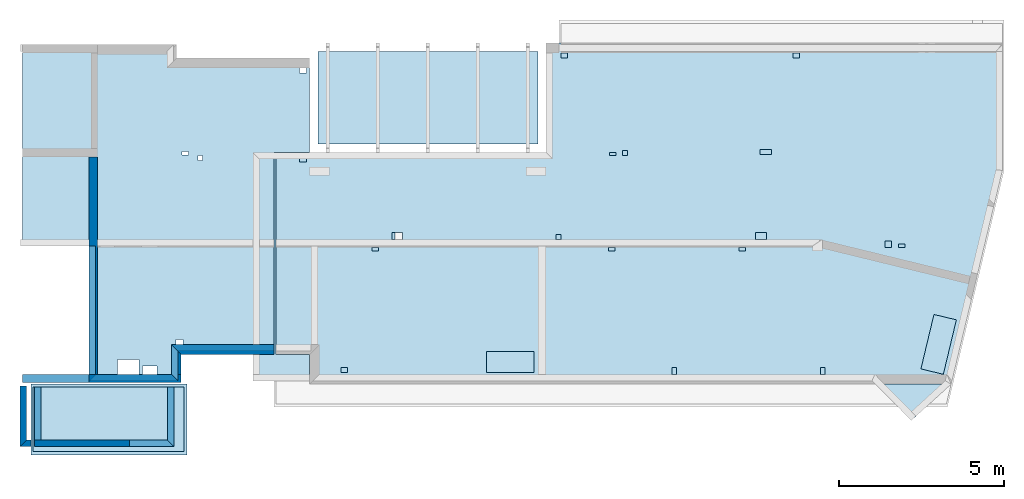
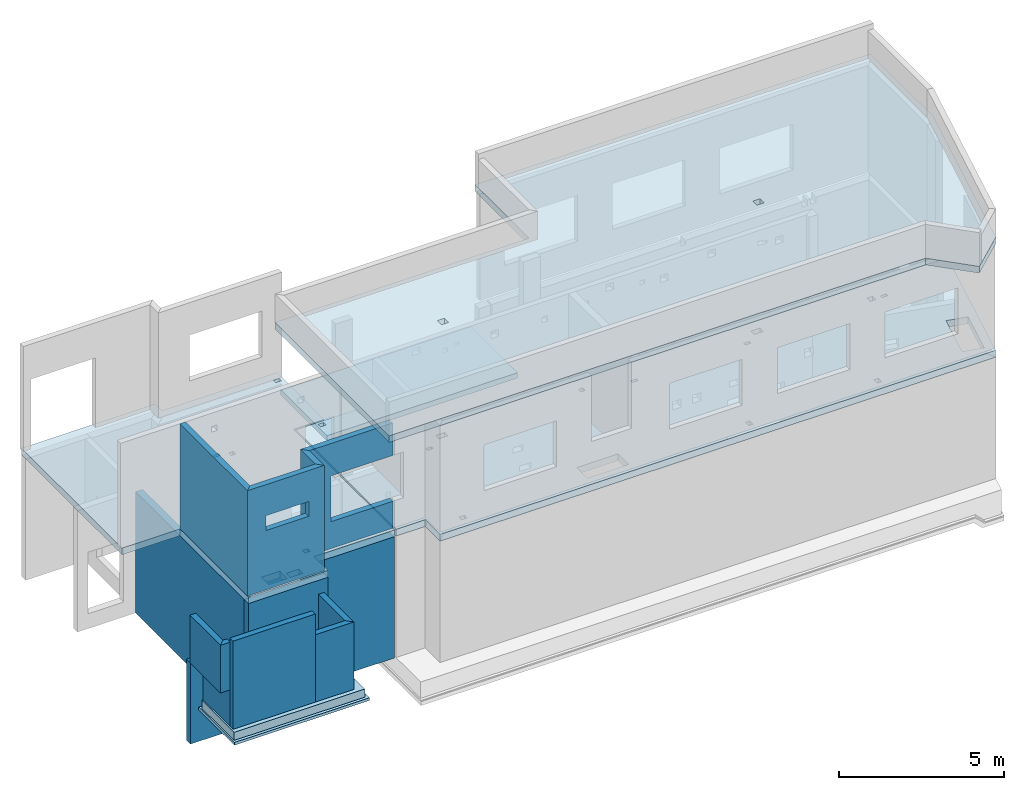
# One storey, part 1 of 7: 15 walls, 6 slabs, 29 openings.
"""IFC2X3 building model written with IfcOpenShell, lengths in millimetres."""

from ifc_helpers import new_model, entity, si_unit, converted_unit, derived_unit, money_unit, direction, frame, frame_2d, origin_with_axes, place, context, subcontext, project, spatial, polyline, rectangle, outline, extrude, material, layer, layer_set, layer_usage, type_object, element, save


model = new_model("IFC2X3")

# Units and contexts
model_context = context("Model", 3, precision=1e-05, world=origin_with_axes(), true_north=direction((0.0, 1.0)))
body_context = subcontext(model_context, "Body", "Model", "MODEL_VIEW", scale=1.0)
ifc_project = project(units=[si_unit("LENGTHUNIT", "METRE", prefix="MILLI"), si_unit("AREAUNIT", "SQUARE_METRE"), si_unit("VOLUMEUNIT", "CUBIC_METRE"), si_unit("ABSORBEDDOSEUNIT", "GRAY"), si_unit("AMOUNTOFSUBSTANCEUNIT", "MOLE"), si_unit("DOSEEQUIVALENTUNIT", "SIEVERT"), si_unit("ELECTRICCAPACITANCEUNIT", "FARAD"), si_unit("ELECTRICCHARGEUNIT", "COULOMB"), si_unit("ELECTRICCONDUCTANCEUNIT", "SIEMENS"), si_unit("ELECTRICCURRENTUNIT", "AMPERE"), si_unit("ELECTRICRESISTANCEUNIT", "OHM"), si_unit("ELECTRICVOLTAGEUNIT", "VOLT"), si_unit("ENERGYUNIT", "JOULE"), si_unit("FORCEUNIT", "NEWTON"), si_unit("FREQUENCYUNIT", "HERTZ"), si_unit("ILLUMINANCEUNIT", "LUX"), si_unit("INDUCTANCEUNIT", "HENRY"), si_unit("LUMINOUSFLUXUNIT", "LUMEN"), si_unit("LUMINOUSINTENSITYUNIT", "CANDELA"), si_unit("MAGNETICFLUXDENSITYUNIT", "TESLA"), si_unit("MAGNETICFLUXUNIT", "WEBER"), si_unit("MASSUNIT", "GRAM"), converted_unit("PLANEANGLEUNIT", "degree", entity("IfcReal", 0.0174532925199433), si_unit("PLANEANGLEUNIT", "RADIAN"), dimensions=[0, 0, 0, 0, 0, 0, 0]), si_unit("POWERUNIT", "WATT"), si_unit("PRESSUREUNIT", "PASCAL"), si_unit("RADIOACTIVITYUNIT", "BECQUEREL"), si_unit("SOLIDANGLEUNIT", "STERADIAN"), si_unit("THERMODYNAMICTEMPERATUREUNIT", "KELVIN"), si_unit("TIMEUNIT", "SECOND"), derived_unit("ACCELERATIONUNIT", [(si_unit("LENGTHUNIT", "METRE", prefix="MILLI"), 1), (si_unit("TIMEUNIT", "SECOND"), -2)]), derived_unit("ANGULARVELOCITYUNIT", [(converted_unit("PLANEANGLEUNIT", "degree", entity("IfcReal", 0.0174532925199433), si_unit("PLANEANGLEUNIT", "RADIAN"), dimensions=[0, 0, 0, 0, 0, 0, 0]), 1), (si_unit("TIMEUNIT", "SECOND"), -1)]), derived_unit("CURVATUREUNIT", [(converted_unit("PLANEANGLEUNIT", "degree", entity("IfcReal", 0.0174532925199433), si_unit("PLANEANGLEUNIT", "RADIAN"), dimensions=[0, 0, 0, 0, 0, 0, 0]), 1), (si_unit("LENGTHUNIT", "METRE", prefix="MILLI"), -1)]), derived_unit("DYNAMICVISCOSITYUNIT", [(si_unit("PRESSUREUNIT", "PASCAL"), 1), (si_unit("TIMEUNIT", "SECOND"), 1)]), derived_unit("HEATFLUXDENSITYUNIT", [(si_unit("POWERUNIT", "WATT"), 1), (si_unit("LENGTHUNIT", "METRE", prefix="MILLI"), -2)]), derived_unit("HEATINGVALUEUNIT", [(si_unit("ENERGYUNIT", "JOULE"), 1), (si_unit("MASSUNIT", "GRAM"), -1)]), derived_unit("INTEGERCOUNTRATEUNIT", [(si_unit("TIMEUNIT", "SECOND"), -1)]), derived_unit("IONCONCENTRATIONUNIT", [(si_unit("MASSUNIT", "GRAM"), 1), (si_unit("VOLUMEUNIT", "CUBIC_METRE"), -1)]), derived_unit("ISOTHERMALMOISTURECAPACITYUNIT", [(si_unit("VOLUMEUNIT", "CUBIC_METRE"), 1), (si_unit("MASSUNIT", "GRAM"), -1)]), derived_unit("KINEMATICVISCOSITYUNIT", [(si_unit("AREAUNIT", "SQUARE_METRE"), 1), (si_unit("TIMEUNIT", "SECOND"), -1)]), derived_unit("LINEARFORCEUNIT", [(si_unit("FORCEUNIT", "NEWTON"), 1), (si_unit("LENGTHUNIT", "METRE", prefix="MILLI"), -1)]), derived_unit("LINEARMOMENTUNIT", [(si_unit("FORCEUNIT", "NEWTON"), 1), (si_unit("LENGTHUNIT", "METRE", prefix="MILLI"), -1)]), derived_unit("LINEARSTIFFNESSUNIT", [(si_unit("FORCEUNIT", "NEWTON"), 1), (si_unit("LENGTHUNIT", "METRE", prefix="MILLI"), -1)]), derived_unit("LINEARVELOCITYUNIT", [(si_unit("LENGTHUNIT", "METRE", prefix="MILLI"), 1), (si_unit("TIMEUNIT", "SECOND"), -1)]), derived_unit("LUMINOUSINTENSITYDISTRIBUTIONUNIT", [(si_unit("LUMINOUSINTENSITYUNIT", "CANDELA"), 1), (si_unit("LUMINOUSFLUXUNIT", "LUMEN"), -1)]), derived_unit("MASSDENSITYUNIT", [(si_unit("MASSUNIT", "GRAM"), 1), (si_unit("VOLUMEUNIT", "CUBIC_METRE"), -1)]), derived_unit("MASSFLOWRATEUNIT", [(si_unit("MASSUNIT", "GRAM"), 1), (si_unit("TIMEUNIT", "SECOND"), -1)]), derived_unit("MASSPERLENGTHUNIT", [(si_unit("MASSUNIT", "GRAM"), 1), (si_unit("LENGTHUNIT", "METRE", prefix="MILLI"), -1)]), derived_unit("MODULUSOFELASTICITYUNIT", [(si_unit("FORCEUNIT", "NEWTON"), 1), (si_unit("AREAUNIT", "SQUARE_METRE"), -1)]), derived_unit("MODULUSOFLINEARSUBGRADEREACTIONUNIT", [(si_unit("FORCEUNIT", "NEWTON"), 1), (si_unit("LENGTHUNIT", "METRE", prefix="MILLI"), -2)]), derived_unit("MODULUSOFROTATIONALSUBGRADEREACTIONUNIT", [(si_unit("FORCEUNIT", "NEWTON"), 1), (si_unit("LENGTHUNIT", "METRE", prefix="MILLI"), 1)]), derived_unit("MODULUSOFSUBGRADEREACTIONUNIT", [(si_unit("FORCEUNIT", "NEWTON"), 1), (si_unit("VOLUMEUNIT", "CUBIC_METRE"), -1)]), derived_unit("MOISTUREDIFFUSIVITYUNIT", [(si_unit("VOLUMEUNIT", "CUBIC_METRE"), 1), (si_unit("TIMEUNIT", "SECOND"), -1)]), derived_unit("MOLECULARWEIGHTUNIT", [(si_unit("MASSUNIT", "GRAM"), 1), (si_unit("AMOUNTOFSUBSTANCEUNIT", "MOLE"), -1)]), derived_unit("PLANARFORCEUNIT", [(si_unit("FORCEUNIT", "NEWTON"), 1), (si_unit("LENGTHUNIT", "METRE", prefix="MILLI"), -2)]), derived_unit("ROTATIONALFREQUENCYUNIT", [(si_unit("TIMEUNIT", "SECOND"), -1)]), derived_unit("ROTATIONALMASSUNIT", [(si_unit("MASSUNIT", "GRAM"), 1), (si_unit("LENGTHUNIT", "METRE", prefix="MILLI"), 2)]), derived_unit("ROTATIONALSTIFFNESSUNIT", [(si_unit("FORCEUNIT", "NEWTON"), 1), (si_unit("LENGTHUNIT", "METRE", prefix="MILLI"), 1), (converted_unit("PLANEANGLEUNIT", "degree", entity("IfcReal", 0.0174532925199433), si_unit("PLANEANGLEUNIT", "RADIAN"), dimensions=[0, 0, 0, 0, 0, 0, 0]), -1)]), derived_unit("SECTIONAREAINTEGRALUNIT", [(si_unit("LENGTHUNIT", "METRE", prefix="MILLI"), 5)]), derived_unit("SECTIONMODULUSUNIT", [(si_unit("LENGTHUNIT", "METRE", prefix="MILLI"), 3)]), derived_unit("SHEARMODULUSUNIT", [(si_unit("FORCEUNIT", "NEWTON"), 1), (si_unit("AREAUNIT", "SQUARE_METRE"), -1)]), derived_unit("SOUNDPOWERUNIT", [(si_unit("ENERGYUNIT", "JOULE"), 1), (si_unit("TIMEUNIT", "SECOND"), -1)]), derived_unit("SPECIFICHEATCAPACITYUNIT", [(si_unit("FORCEUNIT", "NEWTON"), 1), (si_unit("MASSUNIT", "GRAM"), -1), (si_unit("THERMODYNAMICTEMPERATUREUNIT", "KELVIN"), -1)]), derived_unit("TEMPERATUREGRADIENTUNIT", [(si_unit("THERMODYNAMICTEMPERATUREUNIT", "KELVIN"), 1), (si_unit("LENGTHUNIT", "METRE", prefix="MILLI"), -1)]), derived_unit("THERMALADMITTANCEUNIT", [(si_unit("POWERUNIT", "WATT"), 1), (si_unit("AREAUNIT", "SQUARE_METRE"), -1), (si_unit("THERMODYNAMICTEMPERATUREUNIT", "KELVIN"), -1)]), derived_unit("THERMALCONDUCTANCEUNIT", [(si_unit("POWERUNIT", "WATT"), 1), (si_unit("LENGTHUNIT", "METRE", prefix="MILLI"), -1), (si_unit("THERMODYNAMICTEMPERATUREUNIT", "KELVIN"), -1)]), derived_unit("THERMALEXPANSIONCOEFFICIENTUNIT", [(si_unit("THERMODYNAMICTEMPERATUREUNIT", "KELVIN"), -1)]), derived_unit("THERMALRESISTANCEUNIT", [(si_unit("AREAUNIT", "SQUARE_METRE"), 1), (si_unit("POWERUNIT", "WATT"), -1)]), derived_unit("THERMALTRANSMITTANCEUNIT", [(si_unit("POWERUNIT", "WATT"), 1), (si_unit("AREAUNIT", "SQUARE_METRE"), -1), (si_unit("THERMODYNAMICTEMPERATUREUNIT", "KELVIN"), -1)]), derived_unit("TORQUEUNIT", [(si_unit("FORCEUNIT", "NEWTON"), 1), (si_unit("LENGTHUNIT", "METRE", prefix="MILLI"), 1)]), derived_unit("VAPORPERMEABILITYUNIT", [(si_unit("MASSUNIT", "GRAM"), 1), (si_unit("TIMEUNIT", "SECOND"), -1)]), derived_unit("VOLUMETRICFLOWRATEUNIT", [(si_unit("VOLUMEUNIT", "CUBIC_METRE"), 1), (si_unit("TIMEUNIT", "SECOND"), -1)]), derived_unit("WARPINGCONSTANTUNIT", [(si_unit("LENGTHUNIT", "METRE", prefix="MILLI"), 6)]), derived_unit("WARPINGMOMENTUNIT", [(si_unit("FORCEUNIT", "NEWTON"), 1), (si_unit("LENGTHUNIT", "METRE", prefix="MILLI"), 2)]), money_unit("USD")], contexts=[model_context])

# Site, building, storey
site_placement = place(None, origin_with_axes())
site = spatial("IfcSite", under=ifc_project, at=site_placement, CompositionType="ELEMENT")
building_placement = place(site_placement, origin_with_axes())
building = spatial("IfcBuilding", under=site, at=building_placement, Name="1", CompositionType="ELEMENT")
storey_placement = place(building_placement, frame((0.0, 0.0, -4900.0), z_axis=(0.0, 0.0, 1.0), x_axis=(1.0, 0.0, 0.0)))
storey = spatial("IfcBuildingStorey", under=building, at=storey_placement, CompositionType="ELEMENT", Elevation=-4900.0)

# Slabs
ifc_material_1 = material()
slab_type_1 = type_object("IfcSlabType", PredefinedType="NOTDEFINED")
slab_1_placement = place(storey_placement, frame((5255.0, -290.0, 1300.0), z_axis=(0.0, 0.0, -1.0), x_axis=(0.0, -1.0, 0.0)))
element("IfcSlab", 1, at=slab_1_placement, inside=storey, type_object=slab_type_1, material=ifc_material_1, context=body_context, shape_type="SweptSolid", body=[
    extrude(rectangle(XDim=2160.0, YDim=4735.0, at=frame_2d((1080.0, 2367.5), x_axis=(1.0, 0.0))), origin_with_axes(), (0.0, 0.0, 1.0), 100.0),
])
ifc_material_2 = material()
slab_type_2 = type_object("IfcSlabType", PredefinedType="NOTDEFINED")
slab_2_placement = place(storey_placement, frame((570.0, -390.0, 1600.0), z_axis=(0.0, 0.0, -1.0), x_axis=(1.0, 0.0, 0.0)))
element("IfcSlab", 2, at=slab_2_placement, inside=storey, type_object=slab_type_2, material=ifc_material_2, context=body_context, shape_type="SweptSolid", body=[
    extrude(rectangle(XDim=4585.0, YDim=1960.0, at=frame_2d((2292.5, 980.0), x_axis=(1.0, 0.0))), origin_with_axes(), (0.0, 0.0, 1.0), 300.0),
])
slab_3_placement = place(storey_placement, frame((15905.0, 9810.0, 3900.0), z_axis=(0.0, 0.0, -1.0), x_axis=(0.0, -1.0, 0.0)))
element("IfcSlab", 3, at=slab_3_placement, inside=storey, type_object=slab_type_2, material=ifc_material_2, context=body_context, shape_type="SweptSolid", body=[
    extrude(rectangle(XDim=2820.0, YDim=6680.0, at=frame_2d((1410.0, 3340.0), x_axis=(1.0, 0.0))), origin_with_axes(), (0.0, 0.0, 1.0), 200.0),
])

# Slab, openings
slab_4_placement = place(storey_placement, frame((7950.0, 6690.0, 4750.0), z_axis=(0.0, 0.0, -1.0), x_axis=(1.0, 0.0, 0.0)))
slab_4 = element("IfcSlab", 4, at=slab_4_placement, inside=storey, type_object=slab_type_2, material=ifc_material_2, context=body_context, shape_type="SweptSolid", body=[
    extrude(outline(polyline([(0.0, 0.0), (8255.0, 0.0), (8255.0, -3370.0), (22065.0, -3370.0), (22065.0, 500.0), (20508.864598, 6990.0), (1025.0, 6990.0), (1025.0, 6090.0), (0.0, 6090.0), (0.0, 0.0)])), origin_with_axes(), (0.0, 0.0, 1.0), 250.0),
])
opening_1_placement = place(slab_4_placement, frame((6395.0, 6000.0, 0.0), z_axis=(0.0, 0.0, 1.0), x_axis=(1.0, 0.0, 0.0)))
element("IfcOpeningElement", 5, at=opening_1_placement, cuts=slab_4, ObjectType="Opening", context=body_context, shape_type="SweptSolid", body=[
    extrude(rectangle(XDim=1440.0, YDim=640.0, at=frame_2d((-720.0, 320.0), x_axis=(1.0, 0.0))), frame((0.0, 0.0, 375.0), z_axis=(0.0, 0.0, -1.0), x_axis=(-1.0, 0.0, 0.0)), (0.0, 0.0, 1.0), 750.0),
])
opening_2_placement = place(slab_4_placement, frame((1975.0, 6490.0, 0.0), z_axis=(0.0, 0.0, 1.0), x_axis=(1.0, 0.0, 0.0)))
element("IfcOpeningElement", 6, at=opening_2_placement, cuts=slab_4, ObjectType="Opening", context=body_context, shape_type="SweptSolid", body=[
    extrude(rectangle(XDim=200.0, YDim=150.0, at=frame_2d((-100.0, 75.0), x_axis=(1.0, 0.0))), frame((0.0, 0.0, 375.0), z_axis=(0.0, 0.0, -1.0), x_axis=(-1.0, 0.0, 0.0)), (0.0, 0.0, 1.0), 750.0),
])
opening_3_placement = place(slab_4_placement, frame((725.0, 95.0, 0.0), z_axis=(0.0, 0.0, 1.0), x_axis=(1.0, 0.0, 0.0)))
element("IfcOpeningElement", 7, at=opening_3_placement, cuts=slab_4, ObjectType="Opening", context=body_context, shape_type="SweptSolid", body=[
    extrude(rectangle(XDim=200.0, YDim=150.0, at=frame_2d((-100.0, 75.0), x_axis=(1.0, 0.0))), frame((0.0, 0.0, 375.0), z_axis=(0.0, 0.0, -1.0), x_axis=(-1.0, 0.0, 0.0)), (0.0, 0.0, 1.0), 750.0),
])
opening_4_placement = place(slab_4_placement, frame((2925.0, 2840.0, 0.0), z_axis=(0.0, 0.0, 1.0), x_axis=(1.0, 0.0, 0.0)))
element("IfcOpeningElement", 8, at=opening_4_placement, cuts=slab_4, ObjectType="Opening", context=body_context, shape_type="SweptSolid", body=[
    extrude(rectangle(XDim=200.0, YDim=100.0, at=frame_2d((-100.0, 50.0), x_axis=(1.0, 0.0))), frame((0.0, 0.0, 375.0), z_axis=(0.0, 0.0, -1.0), x_axis=(-1.0, 0.0, 0.0)), (0.0, 0.0, 1.0), 750.0),
])
opening_5_placement = place(slab_4_placement, frame((3525.0, 2390.0, 0.0), z_axis=(0.0, 0.0, 1.0), x_axis=(1.0, 0.0, 0.0)))
element("IfcOpeningElement", 9, at=opening_5_placement, cuts=slab_4, ObjectType="Opening", context=body_context, shape_type="SweptSolid", body=[
    extrude(rectangle(XDim=320.0, YDim=200.0, at=frame_2d((-160.0, 100.0), x_axis=(1.0, 0.0))), frame((0.0, 0.0, 375.0), z_axis=(0.0, 0.0, -1.0), x_axis=(-1.0, 0.0, 0.0)), (0.0, 0.0, 1.0), 750.0),
])
opening_6_placement = place(slab_4_placement, frame((12025.0, 6490.0, 0.0), z_axis=(0.0, 0.0, 1.0), x_axis=(1.0, 0.0, 0.0)))
element("IfcOpeningElement", 10, at=opening_6_placement, cuts=slab_4, ObjectType="Opening", context=body_context, shape_type="SweptSolid", body=[
    extrude(rectangle(XDim=150.0, YDim=200.0, at=frame_2d((-75.0, 100.0), x_axis=(1.0, 0.0))), frame((0.0, 0.0, 375.0), z_axis=(0.0, 0.0, -1.0), x_axis=(-1.0, 0.0, 0.0)), (0.0, 0.0, 1.0), 750.0),
])
opening_7_placement = place(slab_4_placement, frame((16535.0, 6490.0, 0.0), z_axis=(0.0, 0.0, 1.0), x_axis=(1.0, 0.0, 0.0)))
element("IfcOpeningElement", 11, at=opening_7_placement, cuts=slab_4, ObjectType="Opening", context=body_context, shape_type="SweptSolid", body=[
    extrude(rectangle(XDim=150.0, YDim=200.0, at=frame_2d((-75.0, 100.0), x_axis=(1.0, 0.0))), frame((0.0, 0.0, 375.0), z_axis=(0.0, 0.0, -1.0), x_axis=(-1.0, 0.0, 0.0)), (0.0, 0.0, 1.0), 750.0),
])
opening_8_placement = place(slab_4_placement, frame((19591.587691, 4873.641151, 0.0), z_axis=(0.0, 0.0, 1.0), x_axis=(1.0, 0.0, 0.0)))
element("IfcOpeningElement", 12, at=opening_8_placement, cuts=slab_4, ObjectType="Opening", context=body_context, shape_type="SweptSolid", body=[
    extrude(rectangle(XDim=1700.0, YDim=700.0, at=frame_2d((-538.54361, 908.179425), x_axis=(0.23316545, 0.97243708))), frame((0.0, 0.0, 375.0), z_axis=(0.0, 0.0, -1.0), x_axis=(-1.0, 0.0, 0.0)), (0.0, 0.0, 1.0), 750.0),
])
opening_9_placement = place(slab_4_placement, frame((8655.0, -3070.0, 0.0), z_axis=(0.0, 0.0, 1.0), x_axis=(1.0, 0.0, 0.0)))
element("IfcOpeningElement", 13, at=opening_9_placement, cuts=slab_4, ObjectType="Opening", context=body_context, shape_type="SweptSolid", body=[
    extrude(rectangle(XDim=200.0, YDim=150.0, at=frame_2d((-100.0, 75.0), x_axis=(1.0, 0.0))), frame((0.0, 0.0, 375.0), z_axis=(0.0, 0.0, -1.0), x_axis=(-1.0, 0.0, 0.0)), (0.0, 0.0, 1.0), 750.0),
])
opening_10_placement = place(slab_4_placement, frame((15705.0, -3070.0, 0.0), z_axis=(0.0, 0.0, 1.0), x_axis=(1.0, 0.0, 0.0)))
element("IfcOpeningElement", 14, at=opening_10_placement, cuts=slab_4, ObjectType="Opening", context=body_context, shape_type="SweptSolid", body=[
    extrude(rectangle(XDim=200.0, YDim=150.0, at=frame_2d((-100.0, 75.0), x_axis=(1.0, 0.0))), frame((0.0, 0.0, 375.0), z_axis=(0.0, 0.0, -1.0), x_axis=(-1.0, 0.0, 0.0)), (0.0, 0.0, 1.0), 750.0),
])
opening_11_placement = place(slab_4_placement, frame((10135.0, -50.0, 0.0), z_axis=(0.0, 0.0, 1.0), x_axis=(1.0, 0.0, 0.0)))
element("IfcOpeningElement", 15, at=opening_11_placement, cuts=slab_4, ObjectType="Opening", context=body_context, shape_type="SweptSolid", body=[
    extrude(rectangle(XDim=200.0, YDim=100.0, at=frame_2d((-100.0, 50.0), x_axis=(1.0, 0.0))), frame((0.0, 0.0, 375.0), z_axis=(0.0, 0.0, -1.0), x_axis=(-1.0, 0.0, 0.0)), (0.0, 0.0, 1.0), 750.0),
])
opening_12_placement = place(slab_4_placement, frame((10535.0, -100.0, 0.0), z_axis=(0.0, 0.0, 1.0), x_axis=(1.0, 0.0, 0.0)))
element("IfcOpeningElement", 16, at=opening_12_placement, cuts=slab_4, ObjectType="Opening", context=body_context, shape_type="SweptSolid", body=[
    extrude(rectangle(XDim=150.0, YDim=150.0, at=frame_2d((-75.0, 75.0), x_axis=(1.0, 0.0))), frame((0.0, 0.0, 375.0), z_axis=(0.0, 0.0, -1.0), x_axis=(-1.0, 0.0, 0.0)), (0.0, 0.0, 1.0), 750.0),
])
opening_13_placement = place(slab_4_placement, frame((14705.0, -130.0, 0.0), z_axis=(0.0, 0.0, 1.0), x_axis=(1.0, 0.0, 0.0)))
element("IfcOpeningElement", 17, at=opening_13_placement, cuts=slab_4, ObjectType="Opening", context=body_context, shape_type="SweptSolid", body=[
    extrude(rectangle(XDim=350.0, YDim=150.0, at=frame_2d((-175.0, 75.0), x_axis=(1.0, 0.0))), frame((0.0, 0.0, 375.0), z_axis=(0.0, 0.0, -1.0), x_axis=(-1.0, 0.0, 0.0)), (0.0, 0.0, 1.0), 750.0),
])
opening_14_placement = place(slab_4_placement, frame((8505.0, 2440.0, 0.0), z_axis=(0.0, 0.0, 1.0), x_axis=(1.0, 0.0, 0.0)))
element("IfcOpeningElement", 18, at=opening_14_placement, cuts=slab_4, ObjectType="Opening", context=body_context, shape_type="SweptSolid", body=[
    extrude(rectangle(XDim=150.0, YDim=150.0, at=frame_2d((-75.0, 75.0), x_axis=(1.0, 0.0))), frame((0.0, 0.0, 375.0), z_axis=(0.0, 0.0, -1.0), x_axis=(-1.0, 0.0, 0.0)), (0.0, 0.0, 1.0), 750.0),
])
opening_15_placement = place(slab_4_placement, frame((10105.0, 2840.0, 0.0), z_axis=(0.0, 0.0, 1.0), x_axis=(1.0, 0.0, 0.0)))
element("IfcOpeningElement", 19, at=opening_15_placement, cuts=slab_4, ObjectType="Opening", context=body_context, shape_type="SweptSolid", body=[
    extrude(rectangle(XDim=200.0, YDim=100.0, at=frame_2d((-100.0, 50.0), x_axis=(1.0, 0.0))), frame((0.0, 0.0, 375.0), z_axis=(0.0, 0.0, -1.0), x_axis=(-1.0, 0.0, 0.0)), (0.0, 0.0, 1.0), 750.0),
])
opening_16_placement = place(slab_4_placement, frame((14065.0, 2840.0, 0.0), z_axis=(0.0, 0.0, 1.0), x_axis=(1.0, 0.0, 0.0)))
element("IfcOpeningElement", 20, at=opening_16_placement, cuts=slab_4, ObjectType="Opening", context=body_context, shape_type="SweptSolid", body=[
    extrude(rectangle(XDim=200.0, YDim=100.0, at=frame_2d((-100.0, 50.0), x_axis=(1.0, 0.0))), frame((0.0, 0.0, 375.0), z_axis=(0.0, 0.0, -1.0), x_axis=(-1.0, 0.0, 0.0)), (0.0, 0.0, 1.0), 750.0),
])
opening_17_placement = place(slab_4_placement, frame((14575.0, 2390.0, 0.0), z_axis=(0.0, 0.0, 1.0), x_axis=(1.0, 0.0, 0.0)))
element("IfcOpeningElement", 21, at=opening_17_placement, cuts=slab_4, ObjectType="Opening", context=body_context, shape_type="SweptSolid", body=[
    extrude(rectangle(XDim=320.0, YDim=200.0, at=frame_2d((-160.0, 100.0), x_axis=(1.0, 0.0))), frame((0.0, 0.0, 375.0), z_axis=(0.0, 0.0, -1.0), x_axis=(-1.0, 0.0, 0.0)), (0.0, 0.0, 1.0), 750.0),
])
opening_18_placement = place(slab_4_placement, frame((18505.0, 2640.0, 0.0), z_axis=(0.0, 0.0, 1.0), x_axis=(1.0, 0.0, 0.0)))
element("IfcOpeningElement", 22, at=opening_18_placement, cuts=slab_4, ObjectType="Opening", context=body_context, shape_type="SweptSolid", body=[
    extrude(rectangle(XDim=200.0, YDim=200.0, at=frame_2d((-100.0, 100.0), x_axis=(1.0, 0.0))), frame((0.0, 0.0, 375.0), z_axis=(0.0, 0.0, -1.0), x_axis=(-1.0, 0.0, 0.0)), (0.0, 0.0, 1.0), 750.0),
])
opening_19_placement = place(slab_4_placement, frame((18915.0, 2740.0, 0.0), z_axis=(0.0, 0.0, 1.0), x_axis=(1.0, 0.0, 0.0)))
element("IfcOpeningElement", 23, at=opening_19_placement, cuts=slab_4, ObjectType="Opening", context=body_context, shape_type="SweptSolid", body=[
    extrude(rectangle(XDim=200.0, YDim=100.0, at=frame_2d((-100.0, 50.0), x_axis=(1.0, 0.0))), frame((0.0, 0.0, 375.0), z_axis=(0.0, 0.0, -1.0), x_axis=(-1.0, 0.0, 0.0)), (0.0, 0.0, 1.0), 750.0),
])

slab_5_placement = place(storey_placement, frame((8975.0, 9600.0, 4750.0), z_axis=(0.0, 0.0, -1.0), x_axis=(0.0, -1.0, 0.0)))
slab_5 = element("IfcSlab", 24, at=slab_5_placement, inside=storey, type_object=slab_type_2, material=ifc_material_2, context=body_context, shape_type="SweptSolid", body=[
    extrude(outline(polyline([(0.0, 0.0), (2860.0, 0.0), (2860.0, 1075.0), (9000.0, 1075.0), (9000.0, 3900.0), (9850.0, 3900.0), (9850.0, 6695.0), (5700.0, 6695.0), (5700.0, 8725.0), (-410.0, 8725.0), (-410.0, 4035.0), (0.0, 4035.0), (0.0, 0.0)])), origin_with_axes(), (0.0, 0.0, 1.0), 250.0),
])
opening_20_placement = place(slab_5_placement, frame((300.0, 100.0, 0.0), z_axis=(0.0, 0.0, 1.0), x_axis=(1.0, 0.0, 0.0)))
element("IfcOpeningElement", 25, at=opening_20_placement, cuts=slab_5, ObjectType="Opening", context=body_context, shape_type="SweptSolid", body=[
    extrude(rectangle(XDim=200.0, YDim=150.0, at=frame_2d((-75.0, 100.0), x_axis=(0.0, 1.0))), frame((0.0, 0.0, 375.0), z_axis=(0.0, 0.0, -1.0), x_axis=(-1.0, 0.0, 0.0)), (0.0, 0.0, 1.0), 750.0),
])
opening_21_placement = place(slab_5_placement, frame((2960.0, 3245.0, 0.0), z_axis=(0.0, 0.0, 1.0), x_axis=(1.0, 0.0, 0.0)))
element("IfcOpeningElement", 26, at=opening_21_placement, cuts=slab_5, ObjectType="Opening", context=body_context, shape_type="SweptSolid", body=[
    extrude(rectangle(XDim=150.0, YDim=150.0, at=frame_2d((-75.0, 75.0), x_axis=(0.0, 1.0))), frame((0.0, 0.0, 375.0), z_axis=(0.0, 0.0, -1.0), x_axis=(-1.0, 0.0, 0.0)), (0.0, 0.0, 1.0), 750.0),
])
opening_22_placement = place(slab_5_placement, frame((2840.0, 3675.0, 0.0), z_axis=(0.0, 0.0, 1.0), x_axis=(1.0, 0.0, 0.0)))
element("IfcOpeningElement", 27, at=opening_22_placement, cuts=slab_5, ObjectType="Opening", context=body_context, shape_type="SweptSolid", body=[
    extrude(rectangle(XDim=200.0, YDim=100.0, at=frame_2d((-50.0, 100.0), x_axis=(0.0, 1.0))), frame((0.0, 0.0, 375.0), z_axis=(0.0, 0.0, -1.0), x_axis=(-1.0, 0.0, 0.0)), (0.0, 0.0, 1.0), 750.0),
])
opening_23_placement = place(slab_5_placement, frame((9150.0, 5180.0, 0.0), z_axis=(0.0, 0.0, 1.0), x_axis=(1.0, 0.0, 0.0)))
element("IfcOpeningElement", 28, at=opening_23_placement, cuts=slab_5, ObjectType="Opening", context=body_context, shape_type="SweptSolid", body=[
    extrude(rectangle(XDim=650.0, YDim=450.0, at=frame_2d((-225.0, 325.0), x_axis=(0.0, 1.0))), frame((0.0, 0.0, 375.0), z_axis=(0.0, 0.0, -1.0), x_axis=(-1.0, 0.0, 0.0)), (0.0, 0.0, 1.0), 750.0),
])
opening_24_placement = place(slab_5_placement, frame((9350.0, 4630.0, 0.0), z_axis=(0.0, 0.0, 1.0), x_axis=(1.0, 0.0, 0.0)))
element("IfcOpeningElement", 29, at=opening_24_placement, cuts=slab_5, ObjectType="Opening", context=body_context, shape_type="SweptSolid", body=[
    extrude(rectangle(XDim=450.0, YDim=250.0, at=frame_2d((-125.0, 225.0), x_axis=(0.0, 1.0))), frame((0.0, 0.0, 375.0), z_axis=(0.0, 0.0, -1.0), x_axis=(-1.0, 0.0, 0.0)), (0.0, 0.0, 1.0), 750.0),
])
opening_25_placement = place(slab_5_placement, frame((8550.0, 3850.0, 0.0), z_axis=(0.0, 0.0, 1.0), x_axis=(1.0, 0.0, 0.0)))
element("IfcOpeningElement", 30, at=opening_25_placement, cuts=slab_5, ObjectType="Opening", context=body_context, shape_type="SweptSolid", body=[
    extrude(rectangle(XDim=200.0, YDim=150.0, at=frame_2d((-75.0, 100.0), x_axis=(0.0, 1.0))), frame((0.0, 0.0, 375.0), z_axis=(0.0, 0.0, -1.0), x_axis=(-1.0, 0.0, 0.0)), (0.0, 0.0, 1.0), 750.0),
])

slab_6_placement = place(storey_placement, frame((30015.0, 10010.0, 8950.0), z_axis=(0.0, 0.0, -1.0), x_axis=(0.0, -1.0, 0.0)))
slab_6 = element("IfcSlab", 31, at=slab_6_placement, inside=storey, type_object=slab_type_2, material=ifc_material_2, context=body_context, shape_type="SweptSolid", body=[
    extrude(outline(polyline([(0.0, 0.0), (3820.0, 0.0), (10310.0, 1556.135402), (11410.0, 2765.0), (10210.0, 3957.0), (10210.0, 22765.0), (3270.0, 22765.0), (3270.0, 13860.0), (0.0, 13860.0), (0.0, 0.0)])), origin_with_axes(), (0.0, 0.0, 1.0), 250.0),
])
opening_26_placement = place(slab_6_placement, frame((4970.0, 6740.0, 0.0), z_axis=(0.0, 0.0, 1.0), x_axis=(1.0, 0.0, 0.0)))
element("IfcOpeningElement", 32, at=opening_26_placement, cuts=slab_6, ObjectType="Opening", context=body_context, shape_type="SweptSolid", body=[
    extrude(rectangle(XDim=250.0, YDim=250.0, at=frame_2d((-125.0, 125.0), x_axis=(0.0, 1.0))), frame((0.0, 0.0, 375.0), z_axis=(0.0, 0.0, -1.0), x_axis=(-1.0, 0.0, 0.0)), (0.0, 0.0, 1.0), 750.0),
])
opening_27_placement = place(slab_6_placement, frame((5660.0, 18200.0, 0.0), z_axis=(0.0, 0.0, 1.0), x_axis=(1.0, 0.0, 0.0)))
element("IfcOpeningElement", 33, at=opening_27_placement, cuts=slab_6, ObjectType="Opening", context=body_context, shape_type="SweptSolid", body=[
    extrude(rectangle(XDim=250.0, YDim=250.0, at=frame_2d((-125.0, 125.0), x_axis=(0.0, 1.0))), frame((0.0, 0.0, 375.0), z_axis=(0.0, 0.0, -1.0), x_axis=(-1.0, 0.0, 0.0)), (0.0, 0.0, 1.0), 750.0),
])

# Walls
ifc_material_3 = material()
ifc_layer_1 = layer(ifc_material_3, 250.0, ventilated=False)
ifc_layer_set_1 = layer_set([ifc_layer_1])
ifc_layer_usage_1 = layer_usage(ifc_layer_set_1, "AXIS2", "POSITIVE", 0.0)
wall_type = type_object("IfcWallType", PredefinedType="NOTDEFINED")
wall_1_placement = place(storey_placement, frame((2530.0, 0.0, 0.0), z_axis=(0.0, 0.0, 1.0), x_axis=(0.0, 1.0, 0.0)))
element("IfcWallStandardCase", 34, at=wall_1_placement, inside=storey, type_object=wall_type, material=ifc_layer_usage_1, context=body_context, shape_type="SweptSolid", body=[
    extrude(rectangle(XDim=250.0, YDim=6600.0, at=frame_2d((3300.0, 125.0), x_axis=(0.0, -1.0))), origin_with_axes(), (0.0, 0.0, 1.0), 4500.0),
])
ifc_layer_2 = layer(ifc_material_3, 300.0, ventilated=False)
ifc_layer_set_2 = layer_set([ifc_layer_2])
ifc_layer_usage_2 = layer_usage(ifc_layer_set_2, "AXIS2", "POSITIVE", 0.0)
wall_2_placement = place(storey_placement, frame((7900.0, 900.0, 0.0), z_axis=(0.0, 0.0, 1.0), x_axis=(-1.0, 0.0, 0.0)))
element("IfcWallStandardCase", 35, at=wall_2_placement, inside=storey, type_object=wall_type, material=ifc_layer_usage_2, context=body_context, shape_type="SweptSolid", body=[
    extrude(outline(polyline([(2825.0, 300.0), (0.0, 300.0), (0.0, 0.0), (3125.0, 0.0), (2825.0, 300.0)])), origin_with_axes(), (0.0, 0.0, 1.0), 4500.0),
])
wall_3_placement = place(storey_placement, frame((4775.0, 900.0, 0.0), z_axis=(0.0, 0.0, 1.0), x_axis=(0.0, -1.0, 0.0)))
element("IfcWallStandardCase", 36, at=wall_3_placement, inside=storey, type_object=wall_type, material=ifc_layer_usage_2, context=body_context, shape_type="SweptSolid", body=[
    extrude(outline(polyline([(900.0, 300.0), (300.0, 300.0), (0.0, 0.0), (900.0, 0.0), (900.0, 300.0)])), origin_with_axes(), (0.0, 0.0, 1.0), 4500.0),
])
wall_4_placement = place(storey_placement, frame((250.0, -250.0, 0.0), z_axis=(0.0, 0.0, 1.0), x_axis=(1.0, 0.0, 0.0)))
element("IfcWallStandardCase", 37, at=wall_4_placement, inside=storey, type_object=wall_type, material=ifc_layer_usage_1, context=body_context, shape_type="SweptSolid", body=[
    extrude(rectangle(XDim=2030.0, YDim=250.0, at=frame_2d((1015.0, 125.0), x_axis=(1.0, 0.0))), origin_with_axes(), (0.0, 0.0, 1.0), 3000.0),
])
wall_5_placement = place(storey_placement, frame((2280.0, -250.0, 0.0), z_axis=(0.0, 0.0, 1.0), x_axis=(1.0, 0.0, 0.0)))
element("IfcWallStandardCase", 38, at=wall_5_placement, inside=storey, type_object=wall_type, material=ifc_layer_usage_1, context=body_context, shape_type="SweptSolid", body=[
    extrude(rectangle(XDim=2795.0, YDim=250.0, at=frame_2d((1397.5, 125.0), x_axis=(1.0, 0.0))), origin_with_axes(), (0.0, 0.0, 1.0), 4500.0),
])
ifc_layer_3 = layer(ifc_material_3, 200.0, ventilated=False)
ifc_layer_set_3 = layer_set([ifc_layer_3])
ifc_layer_usage_3 = layer_usage(ifc_layer_set_3, "AXIS2", "POSITIVE", 0.0)
wall_6_placement = place(storey_placement, frame((4655.0, -390.0, 1600.0), z_axis=(0.0, 0.0, 1.0), x_axis=(0.0, -1.0, 0.0)))
element("IfcWallStandardCase", 39, at=wall_6_placement, inside=storey, type_object=wall_type, material=ifc_layer_usage_3, context=body_context, shape_type="SweptSolid", body=[
    extrude(outline(polyline([(1810.0, 200.0), (0.0, 200.0), (0.0, 0.0), (1610.0, 0.0), (1810.0, 200.0)])), origin_with_axes(), (0.0, 0.0, 1.0), 2500.0),
])
wall_7_placement = place(storey_placement, frame((4655.0, -2000.0, 1600.0), z_axis=(0.0, 0.0, 1.0), x_axis=(-1.0, 0.0, 0.0)))
element("IfcWallStandardCase", 40, at=wall_7_placement, inside=storey, type_object=wall_type, material=ifc_layer_usage_3, context=body_context, shape_type="SweptSolid", body=[
    extrude(outline(polyline([(-200.0, 200.0), (0.0, 0.0), (1150.0, 0.0), (1150.0, 200.0), (-200.0, 200.0)])), origin_with_axes(), (0.0, 0.0, 1.0), 2500.0),
])
wall_8_placement = place(storey_placement, frame((620.0, -390.0, 1600.0), z_axis=(0.0, 0.0, 1.0), x_axis=(0.0, -1.0, 0.0)))
element("IfcWallStandardCase", 41, at=wall_8_placement, inside=storey, type_object=wall_type, material=ifc_layer_usage_3, context=body_context, shape_type="SweptSolid", body=[
    extrude(rectangle(XDim=1610.0, YDim=200.0, at=frame_2d((805.0, 100.0), x_axis=(-1.0, 0.0))), origin_with_axes(), (0.0, 0.0, 1.0), 1500.0),
])
wall_9_placement = place(storey_placement, frame((620.0, -2200.0, 1600.0), z_axis=(0.0, 0.0, 1.0), x_axis=(1.0, 0.0, 0.0)))
element("IfcWallStandardCase", 42, at=wall_9_placement, inside=storey, type_object=wall_type, material=ifc_layer_usage_3, context=body_context, shape_type="SweptSolid", body=[
    extrude(rectangle(XDim=2885.0, YDim=200.0, at=frame_2d((1442.5, 100.0), x_axis=(1.0, 0.0))), origin_with_axes(), (0.0, 0.0, 1.0), 3270.0),
])
wall_10_placement = place(storey_placement, frame((180.0, -350.0, 3100.0), z_axis=(0.0, 0.0, 1.0), x_axis=(0.0, -1.0, 0.0)))
element("IfcWallStandardCase", 43, at=wall_10_placement, inside=storey, type_object=wall_type, material=ifc_layer_usage_3, context=body_context, shape_type="SweptSolid", body=[
    extrude(outline(polyline([(1650.0, 200.0), (0.0, 200.0), (0.0, 0.0), (1850.0, 0.0), (1650.0, 200.0)])), origin_with_axes(), (0.0, 0.0, 1.0), 1770.0),
])
wall_11_placement = place(storey_placement, frame((180.0, -2200.0, 3100.0), z_axis=(0.0, 0.0, 1.0), x_axis=(1.0, 0.0, 0.0)))
element("IfcWallStandardCase", 44, at=wall_11_placement, inside=storey, type_object=wall_type, material=ifc_layer_usage_3, context=body_context, shape_type="SweptSolid", body=[
    extrude(outline(polyline([(200.0, 200.0), (0.0, 0.0), (340.0, 0.0), (340.0, 200.0), (200.0, 200.0)])), origin_with_axes(), (0.0, 0.0, 1.0), 1770.0),
])
wall_12_placement = place(storey_placement, frame((2280.0, -200.0, 4750.0), z_axis=(0.0, 0.0, 1.0), x_axis=(0.0, 1.0, 0.0)))
element("IfcWallStandardCase", 45, at=wall_12_placement, inside=storey, type_object=wall_type, material=ifc_layer_usage_3, context=body_context, shape_type="SweptSolid", body=[
    extrude(outline(polyline([(0.0, 0.0), (200.0, -200.0), (4100.0, -200.0), (4100.0, 0.0), (0.0, 0.0)])), origin_with_axes(), (0.0, 0.0, 1.0), 3900.0),
])

# Wall, opening
wall_13_placement = place(storey_placement, frame((2280.0, -200.0, 4750.0), z_axis=(0.0, 0.0, 1.0), x_axis=(1.0, 0.0, 0.0)))
wall_13 = element("IfcWallStandardCase", 46, at=wall_13_placement, inside=storey, type_object=wall_type, material=ifc_layer_usage_3, context=body_context, shape_type="SweptSolid", body=[
    extrude(outline(polyline([(2495.0, 200.0), (200.0, 200.0), (0.0, 0.0), (2695.0, 0.0), (2495.0, 200.0)])), origin_with_axes(), (0.0, 0.0, 1.0), 3900.0),
])
opening_28_placement = place(wall_13_placement, frame((650.0, 0.0, 2200.0), z_axis=(0.0, 0.0, 1.0), x_axis=(1.0, 0.0, 0.0)))
element("IfcOpeningElement", 47, at=opening_28_placement, cuts=wall_13, ObjectType="Opening", context=body_context, shape_type="SweptSolid", body=[
    extrude(rectangle(XDim=550.0, YDim=1500.0, at=frame_2d((-750.0, 275.0), x_axis=(0.0, -1.0))), frame((0.0, 0.0, 0.0), z_axis=(0.0, 1.0, 0.0), x_axis=(-1.0, 0.0, 0.0)), (0.0, 0.0, 1.0), 200.0),
])

# Wall
wall_14_placement = place(storey_placement, frame((4975.0, -200.0, 4750.0), z_axis=(0.0, 0.0, 1.0), x_axis=(0.0, 1.0, 0.0)))
element("IfcWallStandardCase", 48, at=wall_14_placement, inside=storey, type_object=wall_type, material=ifc_layer_usage_3, context=body_context, shape_type="SweptSolid", body=[
    extrude(outline(polyline([(1100.005101, 200.0), (200.0, 200.0), (0.0, 0.0), (900.004774, 0.0), (1100.005101, 200.0)])), origin_with_axes(), (0.0, 0.0, 1.0), 3900.0),
])

# Wall, opening
wall_15_placement = place(storey_placement, frame((7900.0, 700.0, 4750.0), z_axis=(0.0, 0.0, 1.0), x_axis=(-1.0, 1.63e-06, 0.0)))
wall_15 = element("IfcWallStandardCase", 49, at=wall_15_placement, inside=storey, type_object=wall_type, material=ifc_layer_usage_3, context=body_context, shape_type="SweptSolid", body=[
    extrude(outline(polyline([(2925.0, 0.0), (0.0, 0.0), (0.0, -200.0), (3125.000326, -200.0), (2925.0, 0.0)])), origin_with_axes(), (0.0, 0.0, 1.0), 3900.0),
])
opening_29_placement = place(wall_15_placement, frame((-375.0, -200.0, 1000.0), z_axis=(0.0, 0.0, 1.0), x_axis=(1.0, 0.0, 0.0)))
element("IfcOpeningElement", 50, at=opening_29_placement, cuts=wall_15, ObjectType="Opening", context=body_context, shape_type="SweptSolid", body=[
    extrude(rectangle(XDim=1700.0, YDim=2550.0, at=frame_2d((-1275.0, 850.0), x_axis=(0.0, -1.0))), frame((0.0, 0.0, 0.0), z_axis=(0.0, 1.0, 0.0), x_axis=(-1.0, 0.0, 0.0)), (0.0, 0.0, 1.0), 200.0),
])

save(model, "model.ifc")
